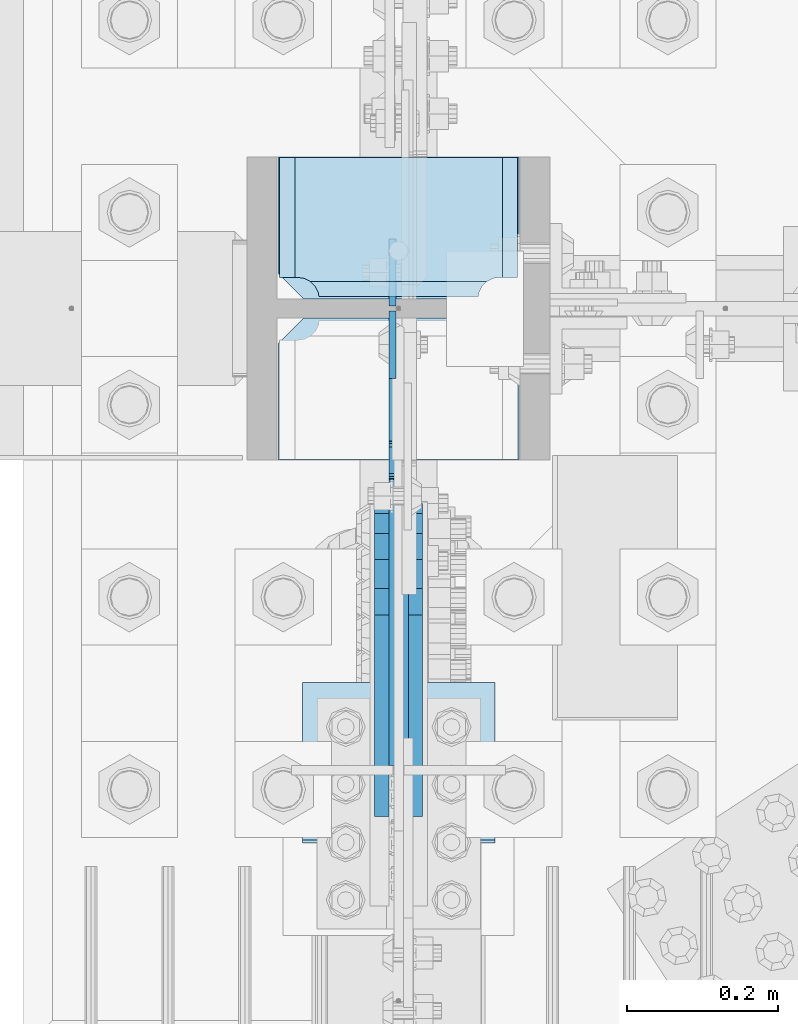
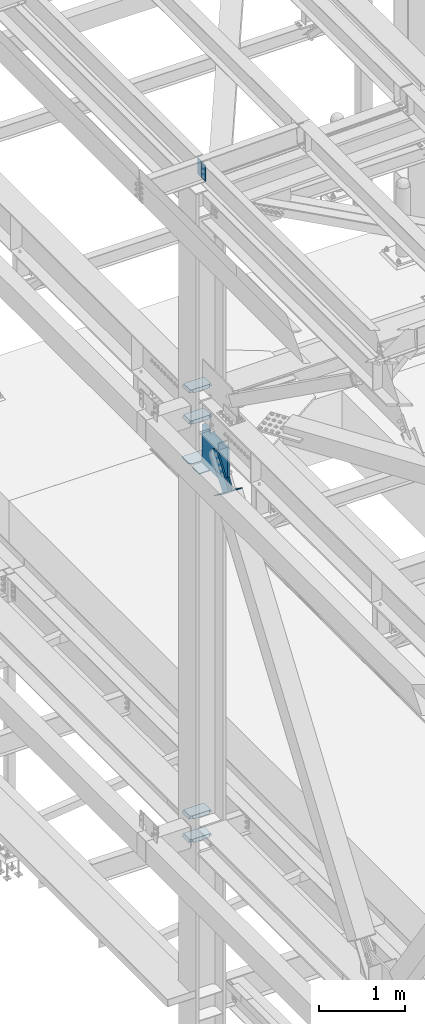
# One storey, part 3362 of 3843: 12 plates, 5 elements without a shape of their own.
"""IFC2X3 building model written with IfcOpenShell, lengths in millimetres."""

from ifc_helpers import new_model, si_unit, frame, origin_with_axes, place, context, subcontext, project, spatial, faceted_brep, material, type_object, element, aggregate, save


model = new_model("IFC2X3")

# Units and contexts
model_context = context("Model", 3, precision=1e-05, world=origin_with_axes())
body_context = subcontext(model_context, "Body", "Model", "MODEL_VIEW")
ifc_project = project(units=[si_unit("LENGTHUNIT", "METRE", prefix="MILLI"), si_unit("AREAUNIT", "SQUARE_METRE"), si_unit("VOLUMEUNIT", "CUBIC_METRE"), si_unit("MASSUNIT", "GRAM", prefix="KILO"), si_unit("TIMEUNIT", "SECOND"), si_unit("PLANEANGLEUNIT", "RADIAN"), si_unit("SOLIDANGLEUNIT", "STERADIAN"), si_unit("THERMODYNAMICTEMPERATUREUNIT", "DEGREE_CELSIUS"), si_unit("LUMINOUSINTENSITYUNIT", "LUMEN")], contexts=[model_context])

# Site, building, storey
site_placement = place(None, origin_with_axes())
site = spatial("IfcSite", under=ifc_project, at=site_placement, CompositionType="ELEMENT")
building_placement = place(site_placement, origin_with_axes())
building = spatial("IfcBuilding", under=site, at=building_placement, Name="Undefined", CompositionType="ELEMENT")
storey_placement = place(building_placement, origin_with_axes())
storey = spatial("IfcBuildingStorey", under=building, at=storey_placement, Name="Undefined", CompositionType="ELEMENT", Elevation=0.0)

# Assembly, plates
assembly_1_placement = place(storey_placement, origin_with_axes())
assembly_1 = element("IfcElementAssembly", 1, at=assembly_1_placement, inside=storey, Name="BEAM", AssemblyPlace="NOTDEFINED", PredefinedType="RIGID_FRAME")
ifc_material_1 = material(Name="STEEL/A572-50")
plate_type_1 = type_object("IfcPlateType", PredefinedType="NOTDEFINED")
plate_1_placement = place(assembly_1_placement, frame((36568.0624999936, 75631.6750000002, 45691.4946293653), z_axis=(0.0, 1.0, 0.0), x_axis=(0.0, 0.0, -1.0)))
plate_1 = element("IfcPlate", 2, at=plate_1_placement, type_object=plate_type_1, material=ifc_material_1, Name="PLATE", context=body_context, shape_type="Brep", body=[
    faceted_brep([(0.0, -4.76249999999709, 0.0), (0.0, -4.76249999999709, 88.9000015258789), (0.0, 4.76249999999709, 88.9000015258789), (0.0, 4.76249999999709, 0.0), (228.600006102781, -4.7625000004191, 88.9000015257589), (228.600006102781, 4.76249999954598, 88.9000015257443), (228.600006103079, -4.7625000004482, 7.27595761418343e-12), (228.600006103079, 4.76249999954598, -7.27595761418343e-12)], [[[0, 1, 2, 3]], [[1, 4, 5, 2]], [[4, 6, 7, 5]], [[6, 0, 3, 7]], [[5, 7, 3, 2]], [[6, 4, 1, 0]]]),
])
plate_2_placement = place(assembly_1_placement, frame((36568.0624999907, 75625.3250000002, 45691.4946293653), z_axis=(0.0, -1.0, 0.0), x_axis=(0.0, 0.0, -1.0)))
plate_2 = element("IfcPlate", 3, at=plate_2_placement, type_object=plate_type_1, material=ifc_material_1, Name="PLATE", context=body_context, shape_type="Brep", body=[
    faceted_brep([(0.0, -4.76249999999709, 0.0), (0.0, -4.76249999999709, 88.9000015258789), (0.0, 4.76249999999709, 88.9000015258789), (0.0, 4.76249999999709, 0.0), (228.600006102781, -4.7625000004191, 88.9000015257589), (228.600006102781, 4.76249999954598, 88.9000015257443), (228.600006103079, -4.7625000004482, 7.27595761418343e-12), (228.600006103079, 4.76249999954598, -7.27595761418343e-12)], [[[0, 1, 2, 3]], [[1, 4, 5, 2]], [[4, 6, 7, 5]], [[6, 0, 3, 7]], [[5, 7, 3, 2]], [[6, 4, 1, 0]]]),
])
aggregate(assembly_1, [plate_1, plate_2])

assembly_2_placement = place(storey_placement, origin_with_axes())
assembly_2 = element("IfcElementAssembly", 4, at=assembly_2_placement, inside=storey, Name="COLUMN", AssemblyPlace="NOTDEFINED", PredefinedType="RIGID_FRAME")
plate_type_2 = type_object("IfcPlateType", PredefinedType="NOTDEFINED")
plate_3_placement = place(assembly_2_placement, frame((36415.6625, 75641.2, 42013.1875), z_axis=(1.0, 0.0, 0.0), x_axis=(0.0, 1.0, 0.0)))
plate_3 = element("IfcPlate", 5, at=plate_3_placement, type_object=plate_type_2, material=ifc_material_1, Name="PLATE", context=body_context, shape_type="Brep", body=[
    faceted_brep([(16.7959640327026, 6.12986484301655, 270.569839531447), (23.117661231503, 17.0792088240414, 276.89153673024), (23.3389576632762, 17.4625000000015, 277.325855432093), (23.3389576632762, 17.4625000000015, 43.3491445679101), (23.1176612314885, 17.0792088240414, 43.7834632697632), (16.7959640327026, 6.12986484301655, 50.1051604685563), (8.83016085001873, -7.66711346669035, 54.1639399157939), (3.17499995231628, -17.4625000000015, 55.059629409523), (3.17499995231628, -17.4625000000015, 265.61537059048), (8.83016085003328, -7.66711346669035, 266.511060084209), (28.5750007629395, 17.4625000000015, 297.336542336721), (28.5750007629395, -17.4625000000015, 317.500500047689), (186.531300000002, -17.4625000000015, 317.500500047689), (186.531300000002, 17.4625000000015, 297.336542336721), (186.531300000002, 17.4625000000015, 23.3384576632816), (186.531300000002, -17.4625000000015, 3.17449995231436), (28.5750007629395, -17.4625000000015, 3.17449995230709), (28.5750007629395, 17.4625000000015, 23.338457663267), (8.83016085001873, -17.4625000000015, 266.511047877182), (16.7959640327026, -17.4625000000015, 270.56982732442), (23.1176612314885, -17.4625000000015, 276.891524523206), (27.1764406787261, -17.4625000000015, 284.857327705889), (27.1764406787261, 17.4625000000015, 284.857327705889), (28.5750007629395, -17.4625000000015, 293.687488555908), (28.5750007629395, 17.4625000000015, 293.687488555908), (28.5750007629395, -17.4625000000015, 26.9874992370605), (28.5750007629395, 17.4625000000015, 26.9874992370605), (27.1764406787261, -17.4625000000015, 35.8176600870793), (27.1764406787261, 17.4625000000015, 35.8176600870793), (23.1176612314885, -17.4625000000015, 43.7834632697632), (16.7959640327026, -17.4625000000015, 50.105160468549), (8.83016085001873, -17.4625000000015, 54.1639399157866)], [[[0, 1, 2, 3, 4, 5, 6, 7, 8, 9]], [[10, 11, 12, 13]], [[14, 15, 16, 17]], [[18, 9, 8]], [[18, 19, 0, 9]], [[19, 20, 1, 0]], [[20, 21, 22, 2, 1]], [[21, 23, 24, 22]], [[24, 23, 11, 10]], [[15, 14, 13, 12]], [[25, 26, 17, 16]], [[25, 27, 28, 26]], [[28, 27, 29, 4, 3]], [[29, 30, 5, 4]], [[30, 31, 6, 5]], [[31, 7, 6]], [[22, 24, 10, 13, 14, 17, 26, 28, 3, 2]], [[31, 30, 29, 27, 25, 16, 15, 12, 11, 23, 21, 20, 19, 18, 8, 7]]]),
])
plate_4_placement = place(assembly_2_placement, frame((36415.6625, 75641.2, 42451.3375), z_axis=(1.0, 0.0, 0.0), x_axis=(0.0, 1.0, 0.0)))
plate_4 = element("IfcPlate", 6, at=plate_4_placement, type_object=plate_type_2, material=ifc_material_1, Name="PLATE", context=body_context, shape_type="Brep", body=[
    faceted_brep([(16.7959640327026, 6.12954035346047, 270.569839531447), (23.117661231503, 17.0792088240414, 276.89153673024), (23.3389576632762, 17.4625000000015, 277.325855432093), (23.3389576632762, 17.4625000000015, 43.3491445679101), (23.1176612314885, 17.0792088240414, 43.7834632697632), (16.7959640327026, 6.12954035346047, 50.1051604685563), (8.83016085001873, -7.6678330078139, 54.1639399157939), (3.17499995231628, -17.4625000000015, 55.059629409523), (3.17499995231628, -17.4625000000015, 265.61537059048), (8.83016085003328, -7.6678330078139, 266.511060084209), (28.5750007629395, 17.4625000000015, 297.336542336721), (28.5750007629395, -17.4625000000015, 317.500500047689), (186.531300000002, -17.4625000000015, 317.500500047689), (186.531300000002, 17.4625000000015, 297.336542336721), (186.531300000002, 17.4625000000015, 23.3384576632816), (186.531300000002, -17.4625000000015, 3.17449995231436), (28.5750007629395, -17.4625000000015, 3.17449995230709), (28.5750007629395, 17.4625000000015, 23.338457663267), (8.83016085001873, -17.4625000000015, 266.511047877182), (16.7959640327026, -17.4625000000015, 270.56982732442), (23.1176612314885, -17.4625000000015, 276.891524523206), (27.1764406787261, -17.4625000000015, 284.857327705889), (27.1764406787261, 17.4625000000015, 284.857327705889), (28.5750007629395, -17.4625000000015, 293.687488555908), (28.5750007629395, 17.4625000000015, 293.687488555908), (28.5750007629395, -17.4625000000015, 26.9874992370605), (28.5750007629395, 17.4625000000015, 26.9874992370605), (27.1764406787261, -17.4625000000015, 35.8176600870793), (27.1764406787261, 17.4625000000015, 35.8176600870793), (23.1176612314885, -17.4625000000015, 43.7834632697632), (16.7959640327026, -17.4625000000015, 50.105160468549), (8.83016085001873, -17.4625000000015, 54.1639399157866)], [[[0, 1, 2, 3, 4, 5, 6, 7, 8, 9]], [[10, 11, 12, 13]], [[14, 15, 16, 17]], [[18, 9, 8]], [[18, 19, 0, 9]], [[19, 20, 1, 0]], [[20, 21, 22, 2, 1]], [[21, 23, 24, 22]], [[24, 23, 11, 10]], [[15, 14, 13, 12]], [[25, 26, 17, 16]], [[25, 27, 28, 26]], [[28, 27, 29, 4, 3]], [[29, 30, 5, 4]], [[30, 31, 6, 5]], [[31, 7, 6]], [[22, 24, 10, 13, 14, 17, 26, 28, 3, 2]], [[31, 30, 29, 27, 25, 16, 15, 12, 11, 23, 21, 20, 19, 18, 8, 7]]]),
])
plate_5_placement = place(assembly_2_placement, frame((36415.6625, 75641.2, 36085.4625), z_axis=(1.0, 0.0, 0.0), x_axis=(0.0, 1.0, 0.0)))
plate_5 = element("IfcPlate", 7, at=plate_5_placement, type_object=plate_type_2, material=ifc_material_1, Name="PLATE", context=body_context, shape_type="Brep", body=[
    faceted_brep([(16.7959640327026, 6.1297025982276, 270.569839531447), (23.117661231503, 17.0792088240414, 276.89153673024), (23.3389576632762, 17.4625000000015, 277.325855432093), (23.3389576632762, 17.4625000000015, 43.3491445679101), (23.1176612314885, 17.0792088240414, 43.7834632697632), (16.7959640327026, 6.1297025982276, 50.1051604685563), (8.830160850026, -7.66747323726304, 54.1639399157939), (3.17499995231628, -17.4625000000015, 55.059629409523), (3.17499995231628, -17.4625000000015, 265.61537059048), (8.830160850026, -7.66747323726304, 266.511060084209), (28.5750007629395, 17.4625000000015, 297.336542336721), (28.5750007629395, -17.4625000000015, 317.500500047689), (186.531300000002, -17.4625000000015, 317.500500047689), (186.531300000002, 17.4625000000015, 297.336542336721), (186.531300000002, 17.4625000000015, 23.3384576632816), (186.531300000002, -17.4625000000015, 3.17449995231436), (28.5750007629395, -17.4625000000015, 3.17449995230709), (28.5750007629395, 17.4625000000015, 23.338457663267), (8.83016085001873, -17.4625000000015, 266.511047877182), (16.7959640327026, -17.4625000000015, 270.56982732442), (23.1176612314885, -17.4625000000015, 276.891524523206), (27.1764406787261, -17.4625000000015, 284.857327705889), (27.1764406787261, 17.4625000000015, 284.857327705889), (28.5750007629395, -17.4625000000015, 293.687488555908), (28.5750007629395, 17.4625000000015, 293.687488555908), (28.5750007629395, -17.4625000000015, 26.9874992370605), (28.5750007629395, 17.4625000000015, 26.9874992370605), (27.1764406787261, -17.4625000000015, 35.8176600870793), (27.1764406787261, 17.4625000000015, 35.8176600870793), (23.1176612314885, -17.4625000000015, 43.7834632697632), (16.7959640327026, -17.4625000000015, 50.105160468549), (8.83016085001873, -17.4625000000015, 54.1639399157866)], [[[0, 1, 2, 3, 4, 5, 6, 7, 8, 9]], [[10, 11, 12, 13]], [[14, 15, 16, 17]], [[18, 9, 8]], [[18, 19, 0, 9]], [[19, 20, 1, 0]], [[20, 21, 22, 2, 1]], [[21, 23, 24, 22]], [[24, 23, 11, 10]], [[15, 14, 13, 12]], [[25, 26, 17, 16]], [[25, 27, 28, 26]], [[28, 27, 29, 4, 3]], [[29, 30, 5, 4]], [[30, 31, 6, 5]], [[31, 7, 6]], [[22, 24, 10, 13, 14, 17, 26, 28, 3, 2]], [[31, 30, 29, 27, 25, 16, 15, 12, 11, 23, 21, 20, 19, 18, 8, 7]]]),
])
plate_6_placement = place(assembly_2_placement, frame((36415.6625, 75641.2, 36418.8375), z_axis=(1.0, 0.0, 0.0), x_axis=(0.0, 1.0, 0.0)))
plate_6 = element("IfcPlate", 8, at=plate_6_placement, type_object=plate_type_2, material=ifc_material_1, Name="PLATE", context=body_context, shape_type="Brep", body=[
    faceted_brep([(16.7959640327026, 6.1297025982276, 270.569839531447), (23.117661231503, 17.0792088240414, 276.89153673024), (23.3389576632762, 17.4625000000015, 277.325855432093), (23.3389576632762, 17.4625000000015, 43.3491445679101), (23.1176612314885, 17.0792088240414, 43.7834632697632), (16.7959640327026, 6.1297025982276, 50.1051604685563), (8.830160850026, -7.66747323726304, 54.1639399157939), (3.17499995231628, -17.4625000000015, 55.059629409523), (3.17499995231628, -17.4625000000015, 265.61537059048), (8.830160850026, -7.66747323726304, 266.511060084209), (28.5750007629395, 17.4625000000015, 297.336542336721), (28.5750007629395, -17.4625000000015, 317.500500047689), (186.531300000002, -17.4625000000015, 317.500500047689), (186.531300000002, 17.4625000000015, 297.336542336721), (186.531300000002, 17.4625000000015, 23.3384576632816), (186.531300000002, -17.4625000000015, 3.17449995231436), (28.5750007629395, -17.4625000000015, 3.17449995230709), (28.5750007629395, 17.4625000000015, 23.338457663267), (8.83016085001873, -17.4625000000015, 266.511047877182), (16.7959640327026, -17.4625000000015, 270.56982732442), (23.1176612314885, -17.4625000000015, 276.891524523206), (27.1764406787261, -17.4625000000015, 284.857327705889), (27.1764406787261, 17.4625000000015, 284.857327705889), (28.5750007629395, -17.4625000000015, 293.687488555908), (28.5750007629395, 17.4625000000015, 293.687488555908), (28.5750007629395, -17.4625000000015, 26.9874992370605), (28.5750007629395, 17.4625000000015, 26.9874992370605), (27.1764406787261, -17.4625000000015, 35.8176600870793), (27.1764406787261, 17.4625000000015, 35.8176600870793), (23.1176612314885, -17.4625000000015, 43.7834632697632), (16.7959640327026, -17.4625000000015, 50.105160468549), (8.83016085001873, -17.4625000000015, 54.1639399157866)], [[[0, 1, 2, 3, 4, 5, 6, 7, 8, 9]], [[10, 11, 12, 13]], [[14, 15, 16, 17]], [[18, 9, 8]], [[18, 19, 0, 9]], [[19, 20, 1, 0]], [[20, 21, 22, 2, 1]], [[21, 23, 24, 22]], [[24, 23, 11, 10]], [[15, 14, 13, 12]], [[25, 26, 17, 16]], [[25, 27, 28, 26]], [[28, 27, 29, 4, 3]], [[29, 30, 5, 4]], [[30, 31, 6, 5]], [[31, 7, 6]], [[22, 24, 10, 13, 14, 17, 26, 28, 3, 2]], [[31, 30, 29, 27, 25, 16, 15, 12, 11, 23, 21, 20, 19, 18, 8, 7]]]),
])

# Assembly, plate
assembly_3_placement = place(storey_placement, origin_with_axes())
assembly_3 = element("IfcElementAssembly", 9, at=assembly_3_placement, inside=storey, AssemblyPlace="NOTDEFINED", PredefinedType="RIGID_FRAME")
ifc_material_2 = material(Name="STEEL/A36")
plate_type_3 = type_object("IfcPlateType", PredefinedType="NOTDEFINED")
plate_7_placement = place(assembly_3_placement, frame((36553.775, 75096.4075649336, 41323.1605411257), z_axis=(0.0, -0.819732546373636, 0.572746499261056), x_axis=(0.0, 0.572746499261054, 0.819732546373637)))
plate_7 = element("IfcPlate", 10, at=plate_7_placement, type_object=plate_type_3, material=ifc_material_2, context=body_context, shape_type="Brep", body=[
    faceted_brep([(0.0, -9.52500000000146, 0.0), (-2.16823536902666e-09, -9.52499999999418, 169.022957228546), (-2.16823536902666e-09, 9.52499999999418, 169.022957228546), (0.0, 9.52500000000146, 0.0), (69.8499999974956, -9.52499999999418, 169.02295722875), (69.8499999974956, 9.52499999999418, 169.02295722875), (171.449999996829, -9.52499999999418, 181.348978614493), (171.449999996829, 9.52499999999418, 181.348978614493), (434.579297661258, -9.52499999999418, 181.348978615235), (434.579297661258, 9.52499999999418, 181.348978615235), (471.63740512668, -9.52499999999418, 173.977662728823), (471.63740512668, 9.52499999999418, 173.977662728823), (503.053751663178, -9.52499999999418, 152.985931091971), (503.053751663178, 9.52499999999418, 152.985931091971), (524.045483300536, -9.52499999999418, 121.569584555793), (524.045483300536, 9.52499999999418, 121.569584555793), (531.416799187516, -9.52499999999418, 84.511480142959), (531.416799187516, 9.52499999999418, 84.511480142959), (524.0454833013, -9.52499999999418, 47.4533726770169), (524.0454833013, 9.52499999999418, 47.4533726770169), (503.053751664252, -9.52499999999418, 16.0370261400676), (503.053751664252, 9.52499999999418, 16.0370261400676), (471.63740512763, -9.52499999999418, -4.95470549746824), (471.63740512763, 9.52499999999418, -4.95470549746824), (434.579299189239, -9.52499999999418, -12.3260213842586), (434.579299189239, 9.52499999999418, -12.3260213842586), (171.44999999931, -9.52499999999418, -12.3260213849862), (171.44999999931, 9.52499999999418, -12.3260213849862), (69.8499999979995, -9.52499999999418, -4.00177668780088e-10), (69.8499999979995, 9.52499999999418, -4.00177668780088e-10)], [[[0, 1, 2, 3]], [[1, 4, 5, 2]], [[4, 6, 7, 5]], [[6, 8, 9, 7]], [[8, 10, 11, 9]], [[10, 12, 13, 11]], [[12, 14, 15, 13]], [[14, 16, 17, 15]], [[16, 18, 19, 17]], [[18, 20, 21, 19]], [[20, 22, 23, 21]], [[22, 24, 25, 23]], [[24, 26, 27, 25]], [[26, 28, 29, 27]], [[28, 0, 3, 29]], [[5, 7, 9, 11, 13, 15, 17, 19, 21, 23, 25, 27, 29, 3, 2]], [[28, 26, 24, 22, 20, 18, 16, 14, 12, 10, 8, 6, 4, 1, 0]]]),
])
aggregate(assembly_3, [plate_7])

assembly_4_placement = place(storey_placement, origin_with_axes())
assembly_4 = element("IfcElementAssembly", 11, at=assembly_4_placement, inside=storey, AssemblyPlace="NOTDEFINED", PredefinedType="RIGID_FRAME")
plate_8_placement = place(assembly_4_placement, frame((36598.225, 75096.4075649336, 41323.1605411257), z_axis=(0.0, -0.819732546373636, 0.572746499261056), x_axis=(0.0, 0.572746499261054, 0.819732546373637)))
plate_8 = element("IfcPlate", 12, at=plate_8_placement, type_object=plate_type_3, material=ifc_material_2, context=body_context, shape_type="Brep", body=[
    faceted_brep([(0.0, -9.52500000000146, 0.0), (-2.16823536902666e-09, -9.52499999999418, 169.022957228546), (-2.16823536902666e-09, 9.52499999999418, 169.022957228546), (0.0, 9.52500000000146, 0.0), (69.8499999974956, -9.52499999999418, 169.02295722875), (69.8499999974956, 9.52499999999418, 169.02295722875), (171.449999996829, -9.52499999999418, 181.348978614493), (171.449999996829, 9.52499999999418, 181.348978614493), (434.579297661258, -9.52499999999418, 181.348978615235), (434.579297661258, 9.52499999999418, 181.348978615235), (471.63740512668, -9.52499999999418, 173.977662728823), (471.63740512668, 9.52499999999418, 173.977662728823), (503.053751663178, -9.52499999999418, 152.985931091971), (503.053751663178, 9.52499999999418, 152.985931091971), (524.045483300536, -9.52499999999418, 121.569584555793), (524.045483300536, 9.52499999999418, 121.569584555793), (531.416799187516, -9.52499999999418, 84.511480142959), (531.416799187516, 9.52499999999418, 84.511480142959), (524.0454833013, -9.52499999999418, 47.4533726770169), (524.0454833013, 9.52499999999418, 47.4533726770169), (503.053751664252, -9.52499999999418, 16.0370261400676), (503.053751664252, 9.52499999999418, 16.0370261400676), (471.63740512763, -9.52499999999418, -4.95470549746824), (471.63740512763, 9.52499999999418, -4.95470549746824), (434.579299189239, -9.52499999999418, -12.3260213842586), (434.579299189239, 9.52499999999418, -12.3260213842586), (171.44999999931, -9.52499999999418, -12.3260213849862), (171.44999999931, 9.52499999999418, -12.3260213849862), (69.8499999979995, -9.52499999999418, -4.00177668780088e-10), (69.8499999979995, 9.52499999999418, -4.00177668780088e-10)], [[[0, 1, 2, 3]], [[1, 4, 5, 2]], [[4, 6, 7, 5]], [[6, 8, 9, 7]], [[8, 10, 11, 9]], [[10, 12, 13, 11]], [[12, 14, 15, 13]], [[14, 16, 17, 15]], [[16, 18, 19, 17]], [[18, 20, 21, 19]], [[20, 22, 23, 21]], [[22, 24, 25, 23]], [[24, 26, 27, 25]], [[26, 28, 29, 27]], [[28, 0, 3, 29]], [[5, 7, 9, 11, 13, 15, 17, 19, 21, 23, 25, 27, 29, 3, 2]], [[28, 26, 24, 22, 20, 18, 16, 14, 12, 10, 8, 6, 4, 1, 0]]]),
])
aggregate(assembly_4, [plate_8])

assembly_5_placement = place(storey_placement, origin_with_axes())
assembly_5 = element("IfcElementAssembly", 13, at=assembly_5_placement, inside=storey, Name="Plate", AssemblyPlace="NOTDEFINED", PredefinedType="RIGID_FRAME")
plate_type_4 = type_object("IfcPlateType", PredefinedType="NOTDEFINED")
plate_9_placement = place(assembly_5_placement, frame((36703.0, 75133.0552589466, 41301.4280399727), z_axis=(0.0, -0.819732546373636, 0.572746499261056), x_axis=(-1.0, 0.0, 0.0)))
plate_9 = element("IfcPlate", 14, at=plate_9_placement, type_object=plate_type_4, material=ifc_material_2, Name="Plate", context=body_context, shape_type="Brep", body=[
    faceted_brep([(0.0, -3.17499999999927, 0.0), (0.0, -3.17499999965185, 254.000000005151), (0.0, 3.17500000035216, 254.000000005166), (0.0, 3.17499999999927, 0.0), (254.0, -3.17499999965185, 254.000000005151), (254.0, 3.17500000035216, 254.000000005166), (254.0, -3.17500000000291, 0.0), (254.0, 3.17499999999927, 1.45519152283669e-11)], [[[0, 1, 2, 3]], [[1, 4, 5, 2]], [[4, 6, 7, 5]], [[6, 0, 3, 7]], [[5, 7, 3, 2]], [[6, 4, 1, 0]]]),
])
aggregate(assembly_5, [plate_9])

# Plate
plate_type_5 = type_object("IfcPlateType", PredefinedType="NOTDEFINED")
plate_10_placement = place(assembly_2_placement, frame((36734.75, 75641.2, 41435.7462394457), z_axis=(0.0, 1.0, 0.0), x_axis=(-1.0, 0.0, 0.0)))
plate_10 = element("IfcPlate", 15, at=plate_10_placement, type_object=plate_type_5, material=ifc_material_1, Name="CB_COL", context=body_context, shape_type="Brep", body=[
    faceted_brep([(0.0, -6.34999999999854, 33.3375015258789), (0.0, -6.34999999999854, 187.324999999997), (0.0, 6.34999999999854, 187.324999999997), (0.0, 6.34999999999854, 33.3375015258789), (317.5, -6.34999999999854, 187.324999999997), (317.5, 6.34999999999854, 187.324999999997), (317.499999999985, -6.34999999999854, 33.3375015258789), (317.499999999985, 6.34999999999854, 33.3375015258789), (284.162498474107, -6.34999999999854, 0.0), (284.162498474107, 6.34999999999854, 0.0), (33.3375015258789, -6.34999999999854, 0.0), (33.3375015258789, 6.34999999999854, 0.0)], [[[0, 1, 2, 3]], [[1, 4, 5, 2]], [[4, 6, 7, 5]], [[6, 8, 9, 7]], [[8, 10, 11, 9]], [[10, 0, 3, 11]], [[5, 7, 9, 11, 3, 2]], [[10, 8, 6, 4, 1, 0]]]),
])

plate_11_placement = place(assembly_2_placement, frame((36734.75, 75615.8, 41435.7462394457), z_axis=(0.0, -1.0, 0.0), x_axis=(-1.0, 0.0, 0.0)))
plate_11 = element("IfcPlate", 16, at=plate_11_placement, type_object=plate_type_5, material=ifc_material_1, Name="CB_COL", context=body_context, shape_type="Brep", body=[
    faceted_brep([(0.0, -6.34999999999854, 33.3375015258789), (0.0, -6.34999999999854, 187.324999999997), (0.0, 6.34999999999854, 187.324999999997), (0.0, 6.34999999999854, 33.3375015258789), (317.5, -6.34999999999854, 187.324999999997), (317.5, 6.34999999999854, 187.324999999997), (317.499999999985, -6.34999999999854, 33.3375015258789), (317.499999999985, 6.34999999999854, 33.3375015258789), (284.162498474107, -6.34999999999854, 0.0), (284.162498474107, 6.34999999999854, 0.0), (33.3375015258789, -6.34999999999854, 0.0), (33.3375015258789, 6.34999999999854, 0.0)], [[[0, 1, 2, 3]], [[1, 4, 5, 2]], [[4, 6, 7, 5]], [[6, 8, 9, 7]], [[8, 10, 11, 9]], [[10, 0, 3, 11]], [[5, 7, 9, 11, 3, 2]], [[10, 8, 6, 4, 1, 0]]]),
])

plate_type_6 = type_object("IfcPlateType", PredefinedType="NOTDEFINED")
plate_12_placement = place(assembly_2_placement, frame((36576.0, 75025.1260854391, 41995.725), z_axis=(0.0, 0.0, -1.0), x_axis=(0.0, 1.0, 0.0)))
plate_12 = element("IfcPlate", 17, at=plate_12_placement, type_object=plate_type_6, material=ifc_material_1, Name="CB", context=body_context, shape_type="Brep", body=[
    faceted_brep([(377.948914560926, -12.6999999999971, 0.0), (377.948914560926, 12.6999999999971, 0.0), (377.948914560926, 12.6999999999971, 25.4000001907334), (377.948914560926, -12.6999999999971, 25.4000001907334), (378.91564448351, 12.6999999999971, 30.2600797087798), (378.91564448351, -12.6999999999971, 30.2600797087798), (381.668658383991, 12.6999999999971, 34.3802561769335), (381.668658383991, -12.6999999999971, 34.3802561769335), (385.788834852152, 12.6999999999971, 37.1332700774074), (385.788834852152, -12.6999999999971, 37.1332700774074), (390.648914370191, 12.6999999999971, 38.0999999999985), (390.648914370191, -12.6999999999971, 38.0999999999985), (416.048914751664, 12.6999999999971, 38.0999999999985), (416.048914751664, -12.6999999999971, 38.0999999999985), (420.908994269703, 12.6999999999971, 37.1332700774074), (420.908994269703, -12.6999999999971, 37.1332700774074), (425.029170737864, 12.6999999999971, 34.3802561769335), (425.029170737864, -12.6999999999971, 34.3802561769335), (427.782184638345, 12.6999999999971, 30.2600797087798), (427.782184638345, -12.6999999999971, 30.2600797087798), (428.748914560929, -12.6999999999971, 25.4000001907334), (428.748914560929, 12.6999999999971, 25.4000001907334), (428.748914560929, 12.6999999999971, 0.0), (428.748914560929, -12.6999999999971, 0.0), (0.0, -12.6999999999971, 0.0), (0.0, -12.6999999999971, 413.606560147411), (0.0, 12.6999999999971, 413.606560147411), (0.0, 12.6999999999971, 0.0), (200.404114274686, -12.6999999999971, 553.628760554253), (200.404114274686, 12.6999999999971, 553.628760554253), (571.623915323871, -12.6999999999971, 553.628760554253), (571.623915323871, 12.6999999999971, 553.628760554253), (590.673914560932, -12.6999999999971, 534.578761317192), (590.673914560932, 12.6999999999971, 534.578761317192), (590.673914560932, -12.6999999999971, 19.0499992370605), (590.673914560932, 12.6999999999971, 19.0499992370605), (571.623915323871, -12.6999999999971, 0.0), (571.623915323871, 12.6999999999971, 0.0)], [[[0, 1, 2, 3]], [[3, 2, 4, 5]], [[5, 4, 6, 7]], [[7, 6, 8, 9]], [[9, 8, 10, 11]], [[11, 10, 12, 13]], [[13, 12, 14, 15]], [[15, 14, 16, 17]], [[17, 16, 18, 19]], [[20, 21, 22, 23]], [[19, 18, 21, 20]], [[24, 25, 26, 27]], [[25, 28, 29, 26]], [[28, 30, 31, 29]], [[30, 32, 33, 31]], [[32, 34, 35, 33]], [[34, 36, 37, 35]], [[37, 36, 23, 22]], [[16, 14, 12, 10, 8, 6, 4, 2, 1, 27, 26, 29, 31, 33, 35, 37, 22, 21, 18]], [[24, 27, 1, 0]], [[36, 34, 32, 30, 28, 25, 24, 0, 3, 5, 7, 9, 11, 13, 15, 17, 19, 20, 23]]]),
])

aggregate(assembly_2, [plate_3, plate_4, plate_5, plate_6, plate_10, plate_11, plate_12])

save(model, "model.ifc")
